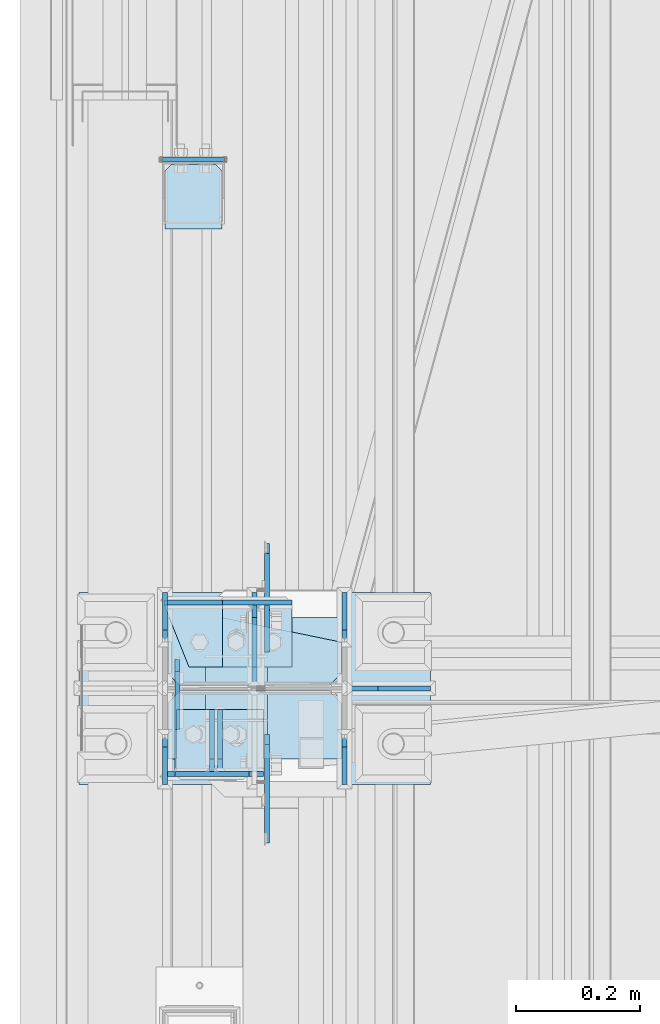
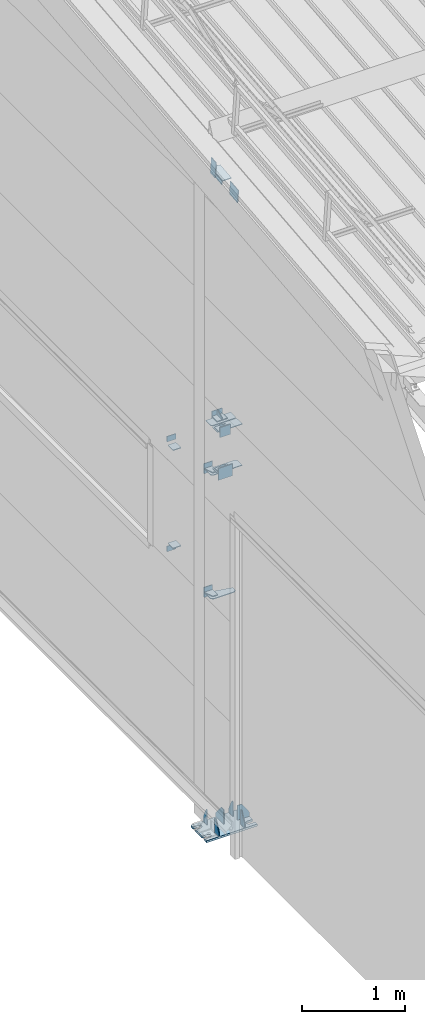
# One storey, part 110 of 709: 33 plates, 4 openings, 10 elements without a shape of their own.
"""IFC4 building model written with IfcOpenShell, lengths in millimetres."""

from ifc_helpers import new_model, si_unit, direction, frame, origin_with_axes, place, context, subcontext, project, spatial, line, arc, indexed_curve, outline, extrude, material, element, aggregate, save


model = new_model("IFC4")

# Units and contexts
model_context = context("Model", 3, precision=0.2, world=origin_with_axes(), true_north=direction((0.0, 1.0)))
body_context = subcontext(model_context, "Body", "Model", "MODEL_VIEW")
ifc_project = project(units=[si_unit("LENGTHUNIT", "METRE", prefix="MILLI"), si_unit("AREAUNIT", "SQUARE_METRE"), si_unit("VOLUMEUNIT", "CUBIC_METRE"), si_unit("MASSUNIT", "GRAM", prefix="KILO"), si_unit("TIMEUNIT", "SECOND"), si_unit("PLANEANGLEUNIT", "RADIAN"), si_unit("SOLIDANGLEUNIT", "STERADIAN"), si_unit("THERMODYNAMICTEMPERATUREUNIT", "DEGREE_CELSIUS"), si_unit("LUMINOUSINTENSITYUNIT", "LUMEN")], contexts=[model_context])

# Site, building, storey
site_placement = place(None, origin_with_axes())
site = spatial("IfcSite", under=ifc_project, at=site_placement, CompositionType="ELEMENT")
building_placement = place(site_placement, origin_with_axes())
building = spatial("IfcBuilding", under=site, at=building_placement, Name="Undefined", CompositionType="ELEMENT")
storey_placement = place(building_placement, origin_with_axes())
storey = spatial("IfcBuildingStorey", under=building, at=storey_placement, Name="Undefined", CompositionType="ELEMENT", Elevation=0.0)

# Assembly, plates, voiding features
assembly_1_placement = place(storey_placement, frame((149.0, 5500.0, -200.0), z_axis=(0.0, -1.0, 0.0), x_axis=(0.0, 0.0, 1.0)))
assembly_1 = element("IfcElementAssembly", 1, at=assembly_1_placement, inside=storey)
ifc_material = material(Name="C355-6", Category="STEEL")
plate_1_placement = place(assembly_1_placement, frame((25.0, -145.0, -74.5), z_axis=(0.0, -1.0, 0.0), x_axis=(0.0, 0.0, -1.0)))
plate_1 = element("IfcPlate", 2, at=plate_1_placement, material=ifc_material, ObjectType="426", context=body_context, shape_type="SolidModel", body=[
    extrude(outline(indexed_curve([(0.0, 0.0), (80.5, 0.0), (80.5, 50.0), (20.0, 175.0), (0.0, 175.0)], segments=[line(1, 2, 3, 4, 5, 1)])), frame((0.0, 0.0, 4.0), z_axis=(0.0, 0.0, 1.0), x_axis=(1.0, 0.0, 0.0)), (0.0, 0.0, -1.0), 8.0),
])
plate_2_placement = place(assembly_1_placement, frame((25.0, -145.0, 74.5), z_axis=(0.0, 1.0, 0.0), x_axis=(0.0, 0.0, 1.0)))
plate_2 = element("IfcPlate", 3, at=plate_2_placement, material=ifc_material, ObjectType="426", context=body_context, shape_type="SolidModel", body=[
    extrude(outline(indexed_curve([(0.0, 0.0), (80.5, 0.0), (80.5, 50.0), (20.0, 175.0), (0.0, 175.0)], segments=[line(1, 2, 3, 4, 5, 1)])), frame((0.0, 0.0, 4.0), z_axis=(0.0, 0.0, 1.0), x_axis=(1.0, 0.0, 0.0)), (0.0, 0.0, -1.0), 8.0),
])
plate_3_placement = place(assembly_1_placement, frame((25.0, 0.0, -2.75), z_axis=(0.0, -1.0, 0.0), x_axis=(0.0, 0.0, -1.0)))
plate_3 = element("IfcPlate", 4, at=plate_3_placement, material=ifc_material, ObjectType="417", context=body_context, shape_type="SolidModel", body=[
    extrude(outline(indexed_curve([(0.0, 0.0), (152.25, 0.0), (152.25, 50.0), (50.0, 175.0), (0.0, 175.0)], segments=[line(1, 2, 3, 4, 5, 1)])), frame((0.0, 0.0, 4.0), z_axis=(0.0, 0.0, 1.0), x_axis=(1.0, 0.0, 0.0)), (0.0, 0.0, -1.0), 8.0),
])
plate_4_placement = place(assembly_1_placement, frame((25.0, 145.0, 74.5), z_axis=(0.0, 1.0, 0.0), x_axis=(0.0, 0.0, 1.0)))
plate_4 = element("IfcPlate", 5, at=plate_4_placement, material=ifc_material, ObjectType="426", context=body_context, shape_type="SolidModel", body=[
    extrude(outline(indexed_curve([(0.0, 0.0), (80.5, 0.0), (80.5, 50.0), (20.0, 175.0), (0.0, 175.0)], segments=[line(1, 2, 3, 4, 5, 1)])), frame((0.0, 0.0, 4.0), z_axis=(0.0, 0.0, 1.0), x_axis=(1.0, 0.0, 0.0)), (0.0, 0.0, -1.0), 8.0),
])
plate_5_placement = place(assembly_1_placement, frame((25.0, -149.0, 0.0), z_axis=(0.0, 0.0, 1.0), x_axis=(0.0, -1.0, 0.0)))
plate_5 = element("IfcPlate", 6, at=plate_5_placement, material=ifc_material, ObjectType="418", context=body_context, shape_type="SolidModel", body=[
    extrude(outline(indexed_curve([(0.0, 0.0), (135.0, 0.0), (135.0, 50.0), (50.0, 175.0), (0.0, 175.0)], segments=[line(1, 2, 3, 4, 5, 1)])), frame((0.0, 0.0, 4.0), z_axis=(0.0, 0.0, 1.0), x_axis=(1.0, 0.0, 0.0)), (0.0, 0.0, -1.0), 8.0),
])
plate_6_placement = place(assembly_1_placement, frame((25.0, 145.0, -74.5), z_axis=(0.0, -1.0, 0.0), x_axis=(0.0, 0.0, -1.0)))
plate_6 = element("IfcPlate", 7, at=plate_6_placement, material=ifc_material, ObjectType="426", context=body_context, shape_type="SolidModel", body=[
    extrude(outline(indexed_curve([(0.0, 0.0), (80.5, 0.0), (80.5, 50.0), (20.0, 175.0), (0.0, 175.0)], segments=[line(1, 2, 3, 4, 5, 1)])), frame((0.0, 0.0, 4.0), z_axis=(0.0, 0.0, 1.0), x_axis=(1.0, 0.0, 0.0)), (0.0, 0.0, -1.0), 8.0),
])
plate_7_placement = place(assembly_1_placement, frame((12.5, -284.0, 155.0), z_axis=(1.0, 0.0, 0.0), x_axis=(0.0, 0.0, -1.0)))
plate_7 = element("IfcPlate", 8, at=plate_7_placement, material=ifc_material, ObjectType="425", context=body_context, shape_type="SolidModel", body=[
    extrude(outline(indexed_curve([(0.0, 0.0), (310.0, 0.0), (310.0, 568.0), (0.0, 568.0)], segments=[line(1, 2, 3, 4, 1)])), frame((0.0, 0.0, 12.5), z_axis=(0.0, 0.0, 1.0), x_axis=(1.0, 0.0, 0.0)), (0.0, 0.0, -1.0), 25.0),
])
voiding_feature_1_placement = place(plate_7_placement, frame((40.0, 568.0, 0.0), z_axis=(0.0, 0.0, -1.0), x_axis=(1.0, 0.0, 0.0)))
element("IfcVoidingFeature", 9, at=voiding_feature_1_placement, cuts=plate_7, PredefinedType="HOLE", context=body_context, shape_type="SolidModel", body=[
    extrude(outline(indexed_curve([(0.0, 0.0), (50.0, 0.0), (50.0, 60.0), (42.67767, 77.67767), (25.0, 85.0), (25.0, 85.0), (7.32233, 77.67767), (0.0, 60.0)], segments=[line(1, 2, 3), arc(3, 4, 5), line(5, 6), arc(6, 7, 8), line(8, 1)])), frame((0.0, 0.0, 12.5), z_axis=(0.0, 0.0, 1.0), x_axis=(1.0, 0.0, 0.0)), (0.0, 0.0, -1.0), 25.0),
])
voiding_feature_2_placement = place(plate_7_placement, frame((40.0, 0.0, 0.0), z_axis=(0.0, 0.0, 1.0), x_axis=(1.0, 0.0, 0.0)))
element("IfcVoidingFeature", 10, at=voiding_feature_2_placement, cuts=plate_7, PredefinedType="HOLE", context=body_context, shape_type="SolidModel", body=[
    extrude(outline(indexed_curve([(0.0, 0.0), (50.0, 0.0), (50.0, 60.0), (42.67767, 77.67767), (25.0, 85.0), (25.0, 85.0), (7.32233, 77.67767), (0.0, 60.0)], segments=[line(1, 2, 3), arc(3, 4, 5), line(5, 6), arc(6, 7, 8), line(8, 1)])), frame((0.0, 0.0, 12.5), z_axis=(0.0, 0.0, 1.0), x_axis=(1.0, 0.0, 0.0)), (0.0, 0.0, -1.0), 25.0),
])
voiding_feature_3_placement = place(plate_7_placement, frame((270.0, 568.0, 0.0), z_axis=(0.0, 0.0, 1.0), x_axis=(-1.0, 0.0, 0.0)))
element("IfcVoidingFeature", 11, at=voiding_feature_3_placement, cuts=plate_7, PredefinedType="HOLE", context=body_context, shape_type="SolidModel", body=[
    extrude(outline(indexed_curve([(0.0, 0.0), (50.0, 0.0), (50.0, 60.0), (42.67767, 77.67767), (25.0, 85.0), (25.0, 85.0), (7.32233, 77.67767), (0.0, 60.0)], segments=[line(1, 2, 3), arc(3, 4, 5), line(5, 6), arc(6, 7, 8), line(8, 1)])), frame((0.0, 0.0, 12.5), z_axis=(0.0, 0.0, 1.0), x_axis=(1.0, 0.0, 0.0)), (0.0, 0.0, -1.0), 25.0),
])
voiding_feature_4_placement = place(plate_7_placement, frame((270.0, 0.0, 0.0), z_axis=(0.0, 0.0, -1.0), x_axis=(-1.0, 0.0, 0.0)))
element("IfcVoidingFeature", 12, at=voiding_feature_4_placement, cuts=plate_7, PredefinedType="HOLE", context=body_context, shape_type="SolidModel", body=[
    extrude(outline(indexed_curve([(0.0, 0.0), (50.0, 0.0), (50.0, 60.0), (42.67767, 77.67767), (25.0, 85.0), (25.0, 85.0), (7.32233, 77.67767), (0.0, 60.0)], segments=[line(1, 2, 3), arc(3, 4, 5), line(5, 6), arc(6, 7, 8), line(8, 1)])), frame((0.0, 0.0, 12.5), z_axis=(0.0, 0.0, 1.0), x_axis=(1.0, 0.0, 0.0)), (0.0, 0.0, -1.0), 25.0),
])
plate_8_placement = place(assembly_1_placement, frame((2742.0, -140.0, -3.75), z_axis=(1.0, 0.0, 0.0), x_axis=(0.0, 0.0, -1.0)))
plate_8 = element("IfcPlate", 13, at=plate_8_placement, material=ifc_material, ObjectType="500", context=body_context, shape_type="SolidModel", body=[
    extrude(outline(indexed_curve([(0.0, 20.0), (20.0, 0.0), (70.75, 0.0), (110.75, 193.0), (110.75, 280.0), (20.0, 280.0), (0.0, 260.0)], segments=[line(1, 2, 3, 4, 5, 6, 7, 1)])), frame((0.0, 0.0, 4.0), z_axis=(0.0, 0.0, 1.0), x_axis=(1.0, 0.0, 0.0)), (0.0, 0.0, -1.0), 8.0),
])
plate_9_placement = place(assembly_1_placement, frame((4212.0, -140.0, -3.75), z_axis=(1.0, 0.0, 0.0), x_axis=(0.0, 0.0, -1.0)))
plate_9 = element("IfcPlate", 14, at=plate_9_placement, material=ifc_material, ObjectType="500", context=body_context, shape_type="SolidModel", body=[
    extrude(outline(indexed_curve([(0.0, 20.0), (20.0, 0.0), (70.75, 0.0), (110.75, 193.0), (110.75, 280.0), (20.0, 280.0), (0.0, 260.0)], segments=[line(1, 2, 3, 4, 5, 6, 7, 1)])), frame((0.0, 0.0, 4.0), z_axis=(0.0, 0.0, 1.0), x_axis=(1.0, 0.0, 0.0)), (0.0, 0.0, -1.0), 8.0),
])
plate_10_placement = place(assembly_1_placement, frame((4802.0, -140.0, -114.5), z_axis=(-1.0, 0.0, 0.0), x_axis=(0.0, 0.0, 1.0)))
plate_10 = element("IfcPlate", 15, at=plate_10_placement, material=ifc_material, ObjectType="529", context=body_context, shape_type="SolidModel", body=[
    extrude(outline(indexed_curve([(0.0, 0.0), (95.75, 0.0), (110.75, 15.0), (110.75, 265.0), (95.75, 280.0), (0.0, 280.0)], segments=[line(1, 2, 3, 4, 5, 6, 1)])), frame((0.0, 0.0, 4.0), z_axis=(0.0, 0.0, 1.0), x_axis=(1.0, 0.0, 0.0)), (0.0, 0.0, -1.0), 8.0),
])
plate_11_placement = place(assembly_1_placement, frame((4312.0, -140.0, 23.75), z_axis=(1.0, 0.0, 0.0), x_axis=(0.0, 0.7071067812, -0.7071067812)))
plate_11 = element("IfcPlate", 16, at=plate_11_placement, material=ifc_material, Name="PLATE", ObjectType="532", context=body_context, shape_type="SolidModel", body=[
    extrude(outline(indexed_curve([(0.0, 0.0), (28.28427, 0.0), (197.9899, 169.70563), (197.9899, 197.9899), (133.81996, 262.15984), (-64.16994, 64.16994)], segments=[line(1, 2, 3, 4, 5, 6, 1)])), frame((0.0, 0.0, 4.0), z_axis=(0.0, 0.0, 1.0), x_axis=(1.0, 0.0, 0.0)), (0.0, 0.0, -1.0), 8.0),
])
plate_12_placement = place(assembly_1_placement, frame((4802.0, 140.0, 114.5), z_axis=(-1.0, 0.0, 0.0), x_axis=(0.0, 0.0, -1.0)))
plate_12 = element("IfcPlate", 17, at=plate_12_placement, material=ifc_material, ObjectType="505", context=body_context, shape_type="SolidModel", body=[
    extrude(outline(indexed_curve([(0.0, 0.0), (95.75, 0.0), (110.75, 15.0), (110.75, 265.0), (95.75, 280.0), (0.0, 280.0)], segments=[line(1, 2, 3, 4, 5, 6, 1)])), frame((0.0, 0.0, 4.0), z_axis=(0.0, 0.0, 1.0), x_axis=(1.0, 0.0, 0.0)), (0.0, 0.0, -1.0), 8.0),
])
aggregate(assembly_1, [plate_1, plate_2, plate_3, plate_4, plate_5, plate_6, plate_7, plate_8, plate_9, plate_10, plate_11, plate_12])

# Assembly, plate
assembly_2_placement = place(storey_placement, frame((162.5, 346.0, 6929.907), z_axis=(1.0, 0.0, 0.0), x_axis=(0.0, 0.9950371902, 0.099503719)))
assembly_2 = element("IfcElementAssembly", 18, at=assembly_2_placement, inside=storey)
plate_13_placement = place(assembly_2_placement, frame((5096.83432, -80.0, 6.5), z_axis=(0.0, 0.0, 1.0), x_axis=(0.0, 1.0, 0.0)))
plate_13 = element("IfcPlate", 19, at=plate_13_placement, material=ifc_material, ObjectType="463", context=body_context, shape_type="SolidModel", body=[
    extrude(outline(indexed_curve([(0.0, 0.0), (160.0, 0.0), (160.0, 160.0), (0.0, 160.0)], segments=[line(1, 2, 3, 4, 1)])), frame((0.0, 0.0, 4.0), z_axis=(0.0, 0.0, 1.0), x_axis=(1.0, 0.0, 0.0)), (0.0, 0.0, -1.0), 8.0),
])
aggregate(assembly_2, [plate_13])

assembly_3_placement = place(storey_placement, frame((162.5, 5500.0, 7445.307), z_axis=(1.0, 0.0, 0.0), x_axis=(0.0, 0.9950371902, 0.099503719)))
assembly_3 = element("IfcElementAssembly", 20, at=assembly_3_placement, inside=storey)
plate_14_placement = place(assembly_3_placement, frame((66.87157, -80.0, 6.5), z_axis=(0.0, 0.0, -1.0), x_axis=(0.0, 1.0, 0.0)))
plate_14 = element("IfcPlate", 21, at=plate_14_placement, material=ifc_material, ObjectType="463", context=body_context, shape_type="SolidModel", body=[
    extrude(outline(indexed_curve([(0.0, 0.0), (160.0, 0.0), (160.0, 160.0), (0.0, 160.0)], segments=[line(1, 2, 3, 4, 1)])), frame((0.0, 0.0, 4.0), z_axis=(0.0, 0.0, 1.0), x_axis=(1.0, 0.0, 0.0)), (0.0, 0.0, -1.0), 8.0),
])
aggregate(assembly_3, [plate_14])

# Assembly, plates
assembly_4_placement = place(storey_placement, frame((50.0, 11000.0, 2550.0), z_axis=(0.0, 0.0, -1.0), x_axis=(0.0, -1.0, 0.0)))
assembly_4 = element("IfcElementAssembly", 22, at=assembly_4_placement, inside=storey)
plate_15_placement = place(assembly_4_placement, frame((5361.5, 47.0, -60.0), z_axis=(-1.0, 0.0, 0.0), x_axis=(0.0, -1.0, 0.0)))
plate_15 = element("IfcPlate", 23, at=plate_15_placement, material=ifc_material, ObjectType="501", context=body_context, shape_type="SolidModel", body=[
    extrude(outline(indexed_curve([(0.0, 0.0), (94.0, 0.0), (94.0, 120.0), (0.0, 120.0)], segments=[line(1, 2, 3, 4, 1)])), frame((0.0, 0.0, 4.0), z_axis=(0.0, 0.0, 1.0), x_axis=(1.0, 0.0, 0.0)), (0.0, 0.0, -1.0), 8.0),
])
plate_16_placement = place(assembly_4_placement, frame((5365.5, 47.0, 0.0), z_axis=(0.0, 0.0, 1.0), x_axis=(0.0, -1.0, 0.0)))
plate_16 = element("IfcPlate", 24, at=plate_16_placement, material=ifc_material, ObjectType="502", context=body_context, shape_type="SolidModel", body=[
    extrude(outline(indexed_curve([(0.0, 0.0), (94.0, 0.0), (94.0, 100.0), (40.0, 100.0), (0.0, 0.0)], segments=[line(1, 2, 3, 4, 5, 1)])), frame((0.0, 0.0, 4.0), z_axis=(0.0, 0.0, 1.0), x_axis=(1.0, 0.0, 0.0)), (0.0, 0.0, -1.0), 8.0),
])
plate_17_placement = place(assembly_4_placement, frame((4646.0, 50.0, -50.0), z_axis=(-1.0, 0.0, 0.0), x_axis=(0.0, 0.0, -1.0)))
plate_17 = element("IfcPlate", 25, at=plate_17_placement, material=ifc_material, ObjectType="509", context=body_context, shape_type="SolidModel", body=[
    extrude(outline(indexed_curve([(0.0, 0.0), (65.0, 0.0), (65.0, 100.0), (0.0, 100.0)], segments=[line(1, 2, 3, 4, 1)])), frame((0.0, 0.0, 4.0), z_axis=(0.0, 0.0, 1.0), x_axis=(1.0, 0.0, 0.0)), (0.0, 0.0, -1.0), 8.0),
])
aggregate(assembly_4, [plate_15, plate_16, plate_17])

assembly_5_placement = place(storey_placement, frame((50.0, 11000.0, 4020.0), z_axis=(0.0, 0.0, -1.0), x_axis=(0.0, -1.0, 0.0)))
assembly_5 = element("IfcElementAssembly", 26, at=assembly_5_placement, inside=storey)
plate_18_placement = place(assembly_5_placement, frame((5365.5, 47.0, 0.0), z_axis=(0.0, 0.0, 1.0), x_axis=(0.0, -1.0, 0.0)))
plate_18 = element("IfcPlate", 27, at=plate_18_placement, material=ifc_material, ObjectType="502", context=body_context, shape_type="SolidModel", body=[
    extrude(outline(indexed_curve([(0.0, 0.0), (94.0, 0.0), (94.0, 100.0), (40.0, 100.0), (0.0, 0.0)], segments=[line(1, 2, 3, 4, 5, 1)])), frame((0.0, 0.0, 4.0), z_axis=(0.0, 0.0, 1.0), x_axis=(1.0, 0.0, 0.0)), (0.0, 0.0, -1.0), 8.0),
])
plate_19_placement = place(assembly_5_placement, frame((5361.5, 47.0, -60.0), z_axis=(-1.0, 0.0, 0.0), x_axis=(0.0, -1.0, 0.0)))
plate_19 = element("IfcPlate", 28, at=plate_19_placement, material=ifc_material, ObjectType="501", context=body_context, shape_type="SolidModel", body=[
    extrude(outline(indexed_curve([(0.0, 0.0), (94.0, 0.0), (94.0, 120.0), (0.0, 120.0)], segments=[line(1, 2, 3, 4, 1)])), frame((0.0, 0.0, 4.0), z_axis=(0.0, 0.0, 1.0), x_axis=(1.0, 0.0, 0.0)), (0.0, 0.0, -1.0), 8.0),
])
plate_20_placement = place(assembly_5_placement, frame((4646.0, -50.0, 50.0), z_axis=(-1.0, 0.0, 0.0), x_axis=(0.0, 0.0, 1.0)))
plate_20 = element("IfcPlate", 29, at=plate_20_placement, material=ifc_material, ObjectType="509", context=body_context, shape_type="SolidModel", body=[
    extrude(outline(indexed_curve([(0.0, 0.0), (65.0, 0.0), (65.0, 100.0), (0.0, 100.0)], segments=[line(1, 2, 3, 4, 1)])), frame((0.0, 0.0, 4.0), z_axis=(0.0, 0.0, 1.0), x_axis=(1.0, 0.0, 0.0)), (0.0, 0.0, -1.0), 8.0),
])
aggregate(assembly_5, [plate_18, plate_19, plate_20])

assembly_6_placement = place(storey_placement, frame((50.0, 6300.0, 2600.0), z_axis=(0.0, -1.0, 0.0), x_axis=(0.0, 0.0, 1.0)))
assembly_6 = element("IfcElementAssembly", 30, at=assembly_6_placement, inside=storey)
plate_21_placement = place(assembly_6_placement, frame((1267.0, -46.0, -46.0), z_axis=(1.0, 0.0, 0.0), x_axis=(0.0, 1.0, 0.0)))
plate_21 = element("IfcPlate", 31, at=plate_21_placement, material=ifc_material, ObjectType="510", context=body_context, shape_type="SolidModel", body=[
    extrude(outline(indexed_curve([(0.0, 10.0), (10.0, 0.0), (82.0, 0.0), (92.0, 10.0), (92.0, 104.0), (0.0, 104.0)], segments=[line(1, 2, 3, 4, 5, 6, 1)])), frame((0.0, 0.0, 4.0), z_axis=(0.0, 0.0, 1.0), x_axis=(1.0, 0.0, 0.0)), (0.0, 0.0, -1.0), 8.0),
])
plate_22_placement = place(assembly_6_placement, frame((103.0, 46.0, -46.0), z_axis=(-1.0, 0.0, 0.0), x_axis=(0.0, -1.0, 0.0)))
plate_22 = element("IfcPlate", 32, at=plate_22_placement, material=ifc_material, ObjectType="510", context=body_context, shape_type="SolidModel", body=[
    extrude(outline(indexed_curve([(0.0, 10.0), (10.0, 0.0), (82.0, 0.0), (92.0, 10.0), (92.0, 104.0), (0.0, 104.0)], segments=[line(1, 2, 3, 4, 5, 6, 1)])), frame((0.0, 0.0, 4.0), z_axis=(0.0, 0.0, 1.0), x_axis=(1.0, 0.0, 0.0)), (0.0, 0.0, -1.0), 8.0),
])
aggregate(assembly_6, [plate_21, plate_22])

assembly_7_placement = place(storey_placement, frame((149.0, 11000.0, 4610.0), z_axis=(0.0, 0.0, -1.0), x_axis=(0.0, -1.0, 0.0)))
assembly_7 = element("IfcElementAssembly", 33, at=assembly_7_placement, inside=storey)
plate_23_placement = place(assembly_7_placement, frame((5465.5, 0.0, -60.0), z_axis=(0.0, -1.0, 0.0), x_axis=(0.0, 0.0, 1.0)))
plate_23 = element("IfcPlate", 34, at=plate_23_placement, material=ifc_material, ObjectType="508", context=body_context, shape_type="SolidModel", body=[
    extrude(outline(indexed_curve([(0.0, 80.0), (36.0, 0.0), (56.0, 0.0), (56.0, 90.0), (46.0, 100.0), (0.0, 100.0)], segments=[line(1, 2, 3, 4, 5, 6, 1)])), frame((0.0, 0.0, 4.0), z_axis=(0.0, 0.0, 1.0), x_axis=(1.0, 0.0, 0.0)), (0.0, 0.0, -1.0), 8.0),
])
plate_24_placement = place(assembly_7_placement, frame((5465.5, -60.0, 0.0), z_axis=(0.0, 0.0, 1.0), x_axis=(0.0, 1.0, 0.0)))
plate_24 = element("IfcPlate", 35, at=plate_24_placement, material=ifc_material, ObjectType="507", context=body_context, shape_type="SolidModel", body=[
    extrude(outline(indexed_curve([(0.0, 0.0), (120.0, 0.0), (120.0, 100.0), (0.0, 100.0)], segments=[line(1, 2, 3, 4, 1)])), frame((0.0, 0.0, 4.0), z_axis=(0.0, 0.0, 1.0), x_axis=(1.0, 0.0, 0.0)), (0.0, 0.0, -1.0), 8.0),
])
plate_25_placement = place(assembly_7_placement, frame((5361.5, -60.0, 60.0), z_axis=(1.0, 0.0, 0.0), x_axis=(0.0, 0.0, -1.0)))
plate_25 = element("IfcPlate", 36, at=plate_25_placement, material=ifc_material, ObjectType="506", context=body_context, shape_type="SolidModel", body=[
    extrude(outline(indexed_curve([(0.0, 0.0), (120.0, 0.0), (120.0, 120.0), (0.0, 120.0)], segments=[line(1, 2, 3, 4, 1)])), frame((0.0, 0.0, 4.0), z_axis=(0.0, 0.0, 1.0), x_axis=(1.0, 0.0, 0.0)), (0.0, 0.0, -1.0), 8.0),
])
aggregate(assembly_7, [plate_23, plate_24, plate_25])

assembly_8_placement = place(storey_placement, frame((80.0, 5500.0, 4610.0), z_axis=(0.0, 0.0, -1.0), x_axis=(0.0, -1.0, 0.0)))
assembly_8 = element("IfcElementAssembly", 37, at=assembly_8_placement, inside=storey)
plate_26_placement = place(assembly_8_placement, frame((34.5, 0.0, -60.0), z_axis=(0.0, 1.0, 0.0), x_axis=(0.0, 0.0, 1.0)))
plate_26 = element("IfcPlate", 38, at=plate_26_placement, material=ifc_material, ObjectType="508", context=body_context, shape_type="SolidModel", body=[
    extrude(outline(indexed_curve([(0.0, 80.0), (36.0, 0.0), (56.0, 0.0), (56.0, 90.0), (46.0, 100.0), (0.0, 100.0)], segments=[line(1, 2, 3, 4, 5, 6, 1)])), frame((0.0, 0.0, 4.0), z_axis=(0.0, 0.0, 1.0), x_axis=(1.0, 0.0, 0.0)), (0.0, 0.0, -1.0), 8.0),
])
plate_27_placement = place(assembly_8_placement, frame((34.5, 60.0, 0.0), z_axis=(0.0, 0.0, 1.0), x_axis=(0.0, -1.0, 0.0)))
plate_27 = element("IfcPlate", 39, at=plate_27_placement, material=ifc_material, ObjectType="507", context=body_context, shape_type="SolidModel", body=[
    extrude(outline(indexed_curve([(0.0, 0.0), (120.0, 0.0), (120.0, 100.0), (0.0, 100.0)], segments=[line(1, 2, 3, 4, 1)])), frame((0.0, 0.0, 4.0), z_axis=(0.0, 0.0, 1.0), x_axis=(1.0, 0.0, 0.0)), (0.0, 0.0, -1.0), 8.0),
])
plate_28_placement = place(assembly_8_placement, frame((138.5, 60.0, 60.0), z_axis=(-1.0, 0.0, 0.0), x_axis=(0.0, 0.0, -1.0)))
plate_28 = element("IfcPlate", 40, at=plate_28_placement, material=ifc_material, ObjectType="506", context=body_context, shape_type="SolidModel", body=[
    extrude(outline(indexed_curve([(0.0, 0.0), (120.0, 0.0), (120.0, 120.0), (0.0, 120.0)], segments=[line(1, 2, 3, 4, 1)])), frame((0.0, 0.0, 4.0), z_axis=(0.0, 0.0, 1.0), x_axis=(1.0, 0.0, 0.0)), (0.0, 0.0, -1.0), 8.0),
])
aggregate(assembly_8, [plate_26, plate_27, plate_28])

assembly_9_placement = place(storey_placement, frame((60.0, 5500.0, 4120.0), z_axis=(0.0, 0.0, -1.0), x_axis=(0.0, -1.0, 0.0)))
assembly_9 = element("IfcElementAssembly", 41, at=assembly_9_placement, inside=storey)
plate_29_placement = place(assembly_9_placement, frame((138.5, 58.0, -70.0), z_axis=(-1.0, 0.0, 0.0), x_axis=(0.0, -1.0, 0.0)))
plate_29 = element("IfcPlate", 42, at=plate_29_placement, material=ifc_material, ObjectType="533", context=body_context, shape_type="SolidModel", body=[
    extrude(outline(indexed_curve([(0.0, 0.0), (161.0, 0.0), (161.0, 140.0), (0.0, 140.0)], segments=[line(1, 2, 3, 4, 1)])), frame((0.0, 0.0, 4.0), z_axis=(0.0, 0.0, 1.0), x_axis=(1.0, 0.0, 0.0)), (0.0, 0.0, -1.0), 8.0),
])
plate_30_placement = place(assembly_9_placement, frame((34.5, -33.0, -70.0), z_axis=(0.0, -1.0, 0.0), x_axis=(1.0, 0.0, 0.0)))
plate_30 = element("IfcPlate", 43, at=plate_30_placement, material=ifc_material, ObjectType="535", context=body_context, shape_type="SolidModel", body=[
    extrude(outline(indexed_curve([(0.0, 50.0), (80.0, 0.0), (100.0, 0.0), (100.0, 70.0), (0.0, 70.0)], segments=[line(1, 2, 3, 4, 5, 1)])), frame((0.0, 0.0, 4.0), z_axis=(0.0, 0.0, 1.0), x_axis=(1.0, 0.0, 0.0)), (0.0, 0.0, -1.0), 8.0),
])
plate_31_placement = place(assembly_9_placement, frame((34.5, 37.0, 0.0), z_axis=(0.0, 0.0, -1.0), x_axis=(1.0, 0.0, 0.0)))
plate_31 = element("IfcPlate", 44, at=plate_31_placement, material=ifc_material, ObjectType="534", context=body_context, shape_type="SolidModel", body=[
    extrude(outline(indexed_curve([(0.0, 0.0), (100.0, 0.0), (100.0, 140.0), (0.0, 140.0)], segments=[line(1, 2, 3, 4, 1)])), frame((0.0, 0.0, 4.0), z_axis=(0.0, 0.0, 1.0), x_axis=(1.0, 0.0, 0.0)), (0.0, 0.0, -1.0), 8.0),
])
aggregate(assembly_9, [plate_29, plate_30, plate_31])

assembly_10_placement = place(storey_placement, frame((0.0, 5490.04963, 7677.42918), z_axis=(0.0, 0.9950371902, 0.099503719), x_axis=(1.0, 0.0, 0.0)))
assembly_10 = element("IfcElementAssembly", 45, at=assembly_10_placement, inside=storey)
plate_32_placement = place(assembly_10_placement, frame((24.0, 97.0, 47.0), z_axis=(-1.0, 0.0, 0.0), x_axis=(0.0, 0.0, -1.0)))
plate_32 = element("IfcPlate", 46, at=plate_32_placement, material=ifc_material, ObjectType="592", context=body_context, shape_type="SolidModel", body=[
    extrude(outline(indexed_curve([(0.0, 0.0), (94.0, 0.0), (94.0, 194.0), (0.0, 194.0)], segments=[line(1, 2, 3, 4, 1)])), frame((0.0, 0.0, 4.0), z_axis=(0.0, 0.0, 1.0), x_axis=(1.0, 0.0, 0.0)), (0.0, 0.0, -1.0), 8.0),
])
plate_33_placement = place(assembly_10_placement, frame((169.5, 103.90074, 110.0), z_axis=(0.0, -1.0, 0.0), x_axis=(-1.0, 0.0, 0.0)))
plate_33 = element("IfcPlate", 47, at=plate_33_placement, material=ifc_material, ObjectType="591", context=body_context, shape_type="SolidModel", body=[
    extrude(outline(indexed_curve([(0.0, 0.0), (100.0, 0.0), (100.0, 220.0), (0.0, 220.0)], segments=[line(1, 2, 3, 4, 1)])), frame((0.0, 0.0, 4.0), z_axis=(0.0, 0.0, 1.0), x_axis=(1.0, 0.0, 0.0)), (0.0, 0.0, -1.0), 8.0),
])
aggregate(assembly_10, [plate_32, plate_33])

save(model, "model.ifc")
